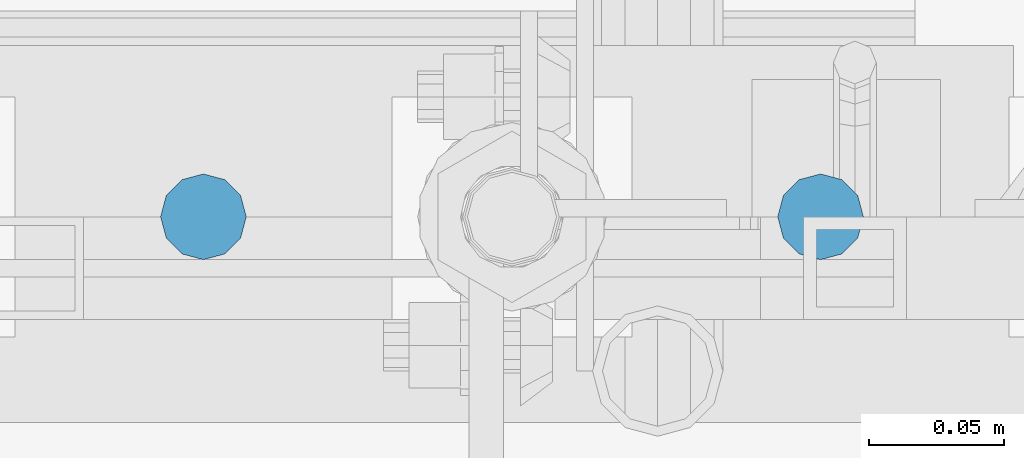
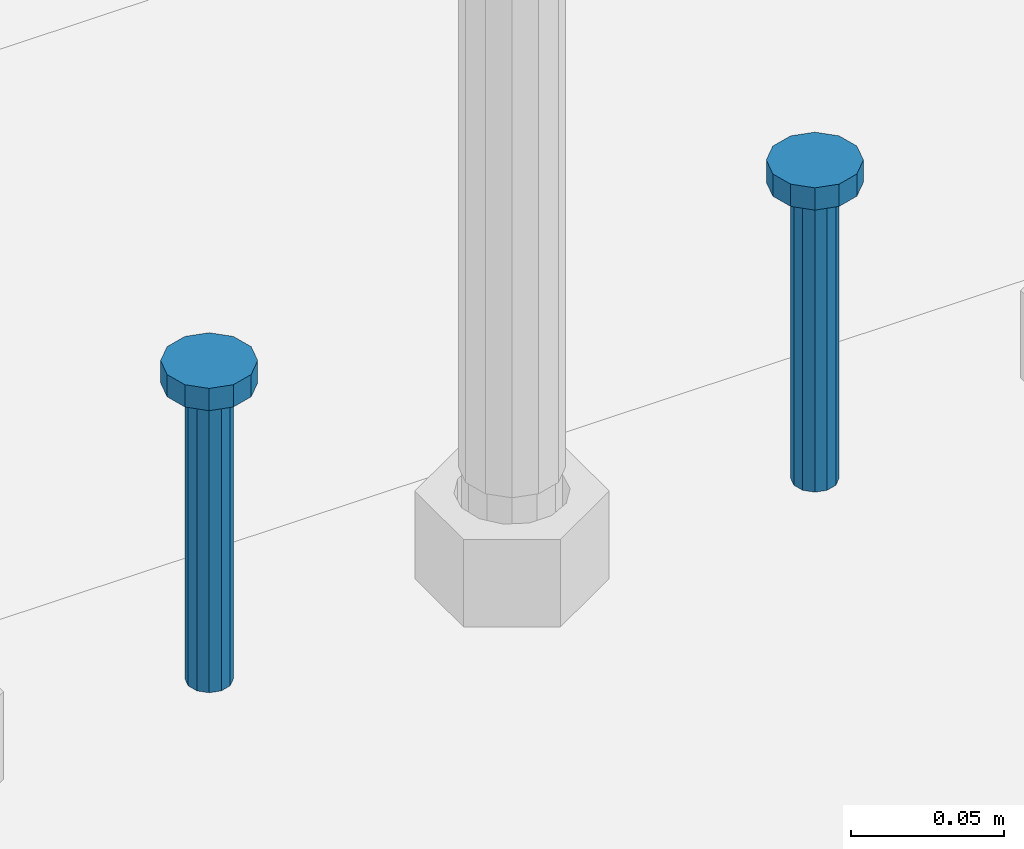
# One storey, part 804 of 1876: 2 columns, 1 element without a shape of its own.
"""IFC2X3 building model written with IfcOpenShell, lengths in millimetres."""

from ifc_helpers import new_model, si_unit, frame, origin_with_axes, place, context, subcontext, project, spatial, faceted_brep, material, type_object, element, aggregate, save


model = new_model("IFC2X3")

# Units and contexts
model_context = context("Model", 3, precision=1e-05, world=origin_with_axes())
body_context = subcontext(model_context, "Body", "Model", "MODEL_VIEW")
ifc_project = project(units=[si_unit("LENGTHUNIT", "METRE", prefix="MILLI"), si_unit("AREAUNIT", "SQUARE_METRE"), si_unit("VOLUMEUNIT", "CUBIC_METRE"), si_unit("MASSUNIT", "GRAM", prefix="KILO"), si_unit("TIMEUNIT", "SECOND"), si_unit("PLANEANGLEUNIT", "RADIAN"), si_unit("SOLIDANGLEUNIT", "STERADIAN"), si_unit("THERMODYNAMICTEMPERATUREUNIT", "DEGREE_CELSIUS"), si_unit("LUMINOUSINTENSITYUNIT", "LUMEN")], contexts=[model_context])

# Site, building, storey
site_placement = place(None, origin_with_axes())
site = spatial("IfcSite", under=ifc_project, at=site_placement, CompositionType="ELEMENT")
building_placement = place(site_placement, origin_with_axes())
building = spatial("IfcBuilding", under=site, at=building_placement, Name="Undefined", CompositionType="ELEMENT")
storey_placement = place(building_placement, origin_with_axes())
storey = spatial("IfcBuildingStorey", under=building, at=storey_placement, Name="Undefined", CompositionType="ELEMENT", Elevation=0.0)

# Assembly, columns
assembly_placement = place(storey_placement, origin_with_axes())
assembly = element("IfcElementAssembly", 1, at=assembly_placement, inside=storey, Name="TEMPLATE", AssemblyPlace="NOTDEFINED", PredefinedType="RIGID_FRAME")
ifc_material = material(Name="STEEL/A108")
column_type = type_object("IfcColumnType", Name="5/8-DIA_HEADED ANCHOR STUD", PredefinedType="NOTDEFINED")
column_1_placement = place(assembly_placement, frame((1841.5, -6883.4, -762.0), z_axis=(1.0, 0.0, 0.0), x_axis=(0.0, 0.0, 1.0)))
column_1 = element("IfcColumn", 2, at=column_1_placement, type_object=column_type, material=ifc_material, Name="HEADED ANCHOR STUD", ObjectType="5/8-DIA_HEADED ANCHOR STUD", context=body_context, shape_type="Brep", body=[
    faceted_brep([(0.0, -7.94000005722046, 0.0), (0.0, -6.86999988555908, -3.97000002861023), (116.84, -6.86999988555908, -3.97000002861023), (116.84, -7.94000005722046, 0.0), (0.0, -3.97000002861023, -6.86999988555908), (116.84, -3.97000002861023, -6.86999988555908), (0.0, 0.0, -7.94000005722046), (116.84, 0.0, -7.94000005722046), (0.0, 3.97000002861023, -6.86999988555908), (116.84, 3.97000002861023, -6.86999988555908), (0.0, 6.86999988555908, -3.97000002861023), (116.84, 6.86999988555908, -3.97000002861023), (0.0, 7.94000005722046, 0.0), (116.84, 7.94000005722046, 0.0), (0.0, 6.86999988555908, 3.97000002861023), (116.84, 6.86999988555908, 3.97000002861023), (0.0, 3.97000002861023, 6.86999988555908), (116.84, 3.97000002861023, 6.86999988555908), (0.0, 0.0, 7.94000005722046), (116.84, 0.0, 7.94000005722046), (0.0, -3.97000002861023, 6.86999988555908), (116.84, -3.97000002861023, 6.86999988555908), (0.0, -6.86999988555908, 3.97000002861023), (116.84, -6.86999988555908, 3.97000002861023), (118.11, -13.75, -7.94000005722046), (118.11, -15.8800001144409, 0.0), (118.11, -7.94000005722046, -13.75), (118.11, 0.0, -15.8800001144409), (118.11, 7.94000005722046, -13.75), (118.11, 13.75, -7.94000005722046), (118.11, 15.8800001144409, 0.0), (118.11, 13.75, 7.94000005722046), (118.11, 7.94000005722046, 13.75), (118.11, 0.0, 15.8800001144409), (118.11, -7.94000005722046, 13.75), (118.11, -13.75, 7.94000005722046), (127.0, -13.75, -7.94000005722046), (127.0, -15.8800001144409, 0.0), (127.0, -7.94000005722046, -13.75), (127.0, 0.0, -15.8800001144409), (127.0, 7.94000005722046, -13.75), (127.0, 13.75, -7.94000005722046), (127.0, 15.8800001144409, 0.0), (127.0, 13.75, 7.94000005722046), (127.0, 7.94000005722046, 13.75), (127.0, 0.0, 15.8800001144409), (127.0, -7.94000005722046, 13.75), (127.0, -13.75, 7.94000005722046)], [[[0, 1, 2, 3]], [[1, 4, 5, 2]], [[4, 6, 7, 5]], [[6, 8, 9, 7]], [[8, 10, 11, 9]], [[10, 12, 13, 11]], [[12, 14, 15, 13]], [[14, 16, 17, 15]], [[16, 18, 19, 17]], [[18, 20, 21, 19]], [[20, 22, 23, 21]], [[22, 0, 3, 23]], [[22, 20, 18, 16, 14, 12, 10, 8, 6, 4, 1, 0]], [[3, 2, 24, 25]], [[2, 5, 26, 24]], [[5, 7, 27, 26]], [[7, 9, 28, 27]], [[9, 11, 29, 28]], [[11, 13, 30, 29]], [[13, 15, 31, 30]], [[15, 17, 32, 31]], [[17, 19, 33, 32]], [[19, 21, 34, 33]], [[21, 23, 35, 34]], [[23, 3, 25, 35]], [[25, 24, 36, 37]], [[24, 26, 38, 36]], [[26, 27, 39, 38]], [[27, 28, 40, 39]], [[28, 29, 41, 40]], [[29, 30, 42, 41]], [[30, 31, 43, 42]], [[31, 32, 44, 43]], [[32, 33, 45, 44]], [[33, 34, 46, 45]], [[34, 35, 47, 46]], [[35, 25, 37, 47]], [[38, 39, 40, 41, 42, 43, 44, 45, 46, 47, 37, 36]]]),
])
column_2_placement = place(assembly_placement, frame((1612.9, -6883.4, -762.0), z_axis=(1.0, 0.0, 0.0), x_axis=(0.0, 0.0, 1.0)))
column_2 = element("IfcColumn", 3, at=column_2_placement, type_object=column_type, material=ifc_material, Name="HEADED ANCHOR STUD", ObjectType="5/8-DIA_HEADED ANCHOR STUD", context=body_context, shape_type="Brep", body=[
    faceted_brep([(0.0, -7.94000005722046, 0.0), (0.0, -6.86999988555908, -3.97000002861023), (116.84, -6.86999988555908, -3.97000002861023), (116.84, -7.94000005722046, 0.0), (0.0, -3.97000002861023, -6.86999988555908), (116.84, -3.97000002861023, -6.86999988555908), (0.0, 0.0, -7.94000005722046), (116.84, 0.0, -7.94000005722046), (0.0, 3.97000002861023, -6.86999988555908), (116.84, 3.97000002861023, -6.86999988555908), (0.0, 6.86999988555908, -3.97000002861023), (116.84, 6.86999988555908, -3.97000002861023), (0.0, 7.94000005722046, 0.0), (116.84, 7.94000005722046, 0.0), (0.0, 6.86999988555908, 3.97000002861023), (116.84, 6.86999988555908, 3.97000002861023), (0.0, 3.97000002861023, 6.86999988555908), (116.84, 3.97000002861023, 6.86999988555908), (0.0, 0.0, 7.94000005722046), (116.84, 0.0, 7.94000005722046), (0.0, -3.97000002861023, 6.86999988555908), (116.84, -3.97000002861023, 6.86999988555908), (0.0, -6.86999988555908, 3.97000002861023), (116.84, -6.86999988555908, 3.97000002861023), (118.11, -13.75, -7.94000005722046), (118.11, -15.8800001144409, 0.0), (118.11, -7.94000005722046, -13.75), (118.11, 0.0, -15.8800001144409), (118.11, 7.94000005722046, -13.75), (118.11, 13.75, -7.94000005722046), (118.11, 15.8800001144409, 0.0), (118.11, 13.75, 7.94000005722046), (118.11, 7.94000005722046, 13.75), (118.11, 0.0, 15.8800001144409), (118.11, -7.94000005722046, 13.75), (118.11, -13.75, 7.94000005722046), (127.0, -13.75, -7.94000005722046), (127.0, -15.8800001144409, 0.0), (127.0, -7.94000005722046, -13.75), (127.0, 0.0, -15.8800001144409), (127.0, 7.94000005722046, -13.75), (127.0, 13.75, -7.94000005722046), (127.0, 15.8800001144409, 0.0), (127.0, 13.75, 7.94000005722046), (127.0, 7.94000005722046, 13.75), (127.0, 0.0, 15.8800001144409), (127.0, -7.94000005722046, 13.75), (127.0, -13.75, 7.94000005722046)], [[[0, 1, 2, 3]], [[1, 4, 5, 2]], [[4, 6, 7, 5]], [[6, 8, 9, 7]], [[8, 10, 11, 9]], [[10, 12, 13, 11]], [[12, 14, 15, 13]], [[14, 16, 17, 15]], [[16, 18, 19, 17]], [[18, 20, 21, 19]], [[20, 22, 23, 21]], [[22, 0, 3, 23]], [[22, 20, 18, 16, 14, 12, 10, 8, 6, 4, 1, 0]], [[3, 2, 24, 25]], [[2, 5, 26, 24]], [[5, 7, 27, 26]], [[7, 9, 28, 27]], [[9, 11, 29, 28]], [[11, 13, 30, 29]], [[13, 15, 31, 30]], [[15, 17, 32, 31]], [[17, 19, 33, 32]], [[19, 21, 34, 33]], [[21, 23, 35, 34]], [[23, 3, 25, 35]], [[25, 24, 36, 37]], [[24, 26, 38, 36]], [[26, 27, 39, 38]], [[27, 28, 40, 39]], [[28, 29, 41, 40]], [[29, 30, 42, 41]], [[30, 31, 43, 42]], [[31, 32, 44, 43]], [[32, 33, 45, 44]], [[33, 34, 46, 45]], [[34, 35, 47, 46]], [[35, 25, 37, 47]], [[38, 39, 40, 41, 42, 43, 44, 45, 46, 47, 37, 36]]]),
])
aggregate(assembly, [column_1, column_2])

save(model, "model.ifc")
